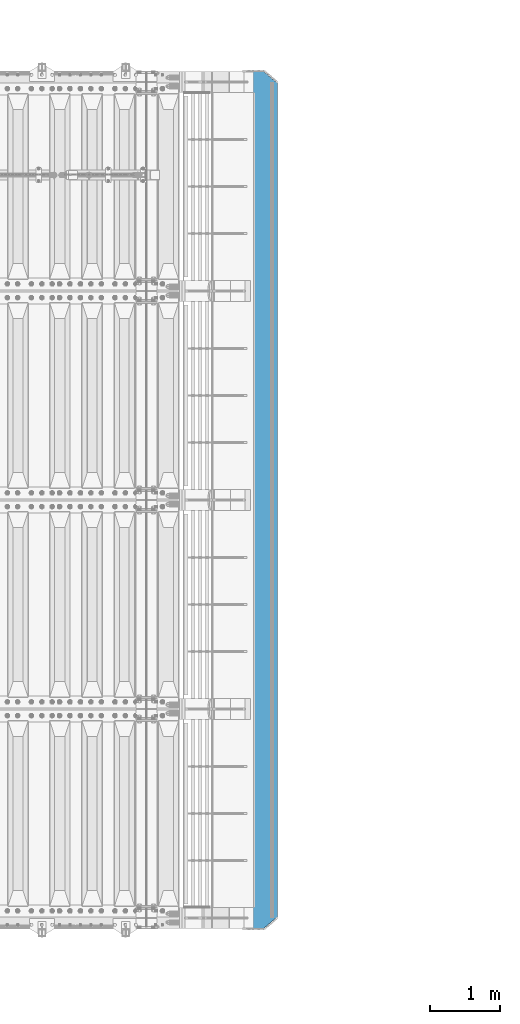
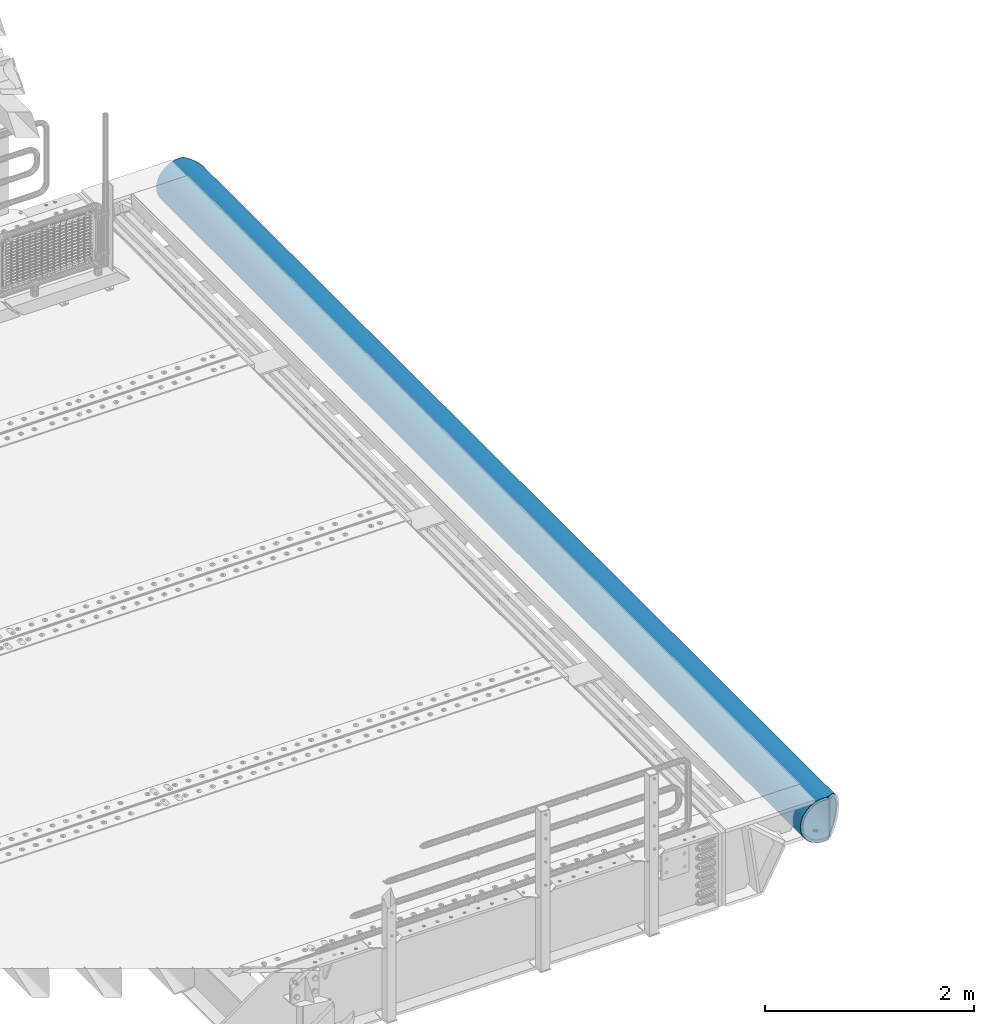
# One storey, part 132 of 257: 1 beam.
"""IFC2X3 building model written with IfcOpenShell, lengths in millimetres."""

import ifcopenshell
import ifcopenshell.guid

model = None  # the IFC model being written
_history = None  # IfcOwnerHistory: only IFC2X3 demands one
_inside = {}  # id of a spatial element -> (the spatial element, [elements in it])
_under = {}  # id of a project, library or spatial element -> (it, [spatial elements below it])
_declared = {}  # id of a project -> (the project, [libraries it declares])
_typed = {}  # id of a type object -> (the type object, [elements of that type])
_made_of = {}  # id of a material, layer set ... -> (it, [elements and type objects made of it])


def new_model(schema):
    """Start an empty IFC model of exactly this schema.

    Asked for "IFC4X3", IfcOpenShell would pick the latest addendum, in which some entities
    have other attributes; the version numbers below select the first issue.
    IFC2X3 requires an IfcOwnerHistory on every rooted entity: one is made here for all.
    """
    global model, _history
    if schema == "IFC4X3":
        model = ifcopenshell.file(schema_version=(4, 3, 0, 0))
    else:
        model = ifcopenshell.file(schema=schema)
    _inside.clear()
    _under.clear()
    _declared.clear()
    _typed.clear()
    _made_of.clear()
    _history = None
    if model.schema == "IFC2X3":
        org = make("IfcOrganization", Name="unknown")
        user = make(
            "IfcPersonAndOrganization",
            ThePerson=make("IfcPerson", FamilyName="unknown"),
            TheOrganization=org,
        )
        app = make(
            "IfcApplication",
            ApplicationDeveloper=org,
            Version="unknown",
            ApplicationFullName="unknown",
            ApplicationIdentifier="unknown",
        )
        _history = make(
            "IfcOwnerHistory",
            OwningUser=user,
            OwningApplication=app,
            ChangeAction="ADDED",
            CreationDate=0,
        )
    return model


def make(cls, **values):
    """One entity of the class cls with the attributes given. An attribute that is None is left unset."""
    return model.create_entity(
        cls, **{name: value for name, value in values.items() if value is not None}
    )


def rooted(cls, **values):
    """An entity with a GlobalId (a new one), such as an element, a storey or a relation."""
    return make(cls, GlobalId=ifcopenshell.guid.new(), OwnerHistory=_history, **values)


def si_unit(unit_type, name, prefix=None):
    """IfcSIUnit, for example si_unit("LENGTHUNIT", "METRE", prefix="MILLI")."""
    return make("IfcSIUnit", UnitType=unit_type, Prefix=prefix, Name=name)


def assignment(units):
    """IfcUnitAssignment: the units of a project."""
    return None if units is None else make("IfcUnitAssignment", Units=units)


def point(xyz):
    """IfcCartesianPoint."""
    return None if xyz is None else make("IfcCartesianPoint", Coordinates=xyz)


def direction(xyz):
    """IfcDirection."""
    return None if xyz is None else make("IfcDirection", DirectionRatios=xyz)


def frame(location, z_axis=None, x_axis=None):
    """IfcAxis2Placement3D, a coordinate frame: its origin and axes. An axis left out is left unset."""
    return make(
        "IfcAxis2Placement3D",
        Location=point(location),
        Axis=direction(z_axis),
        RefDirection=direction(x_axis),
    )


def origin_with_axes():
    """The frame at (0, 0, 0) with the z axis (0, 0, 1) and the x axis (1, 0, 0) written out."""
    return frame((0.0, 0.0, 0.0), z_axis=(0.0, 0.0, 1.0), x_axis=(1.0, 0.0, 0.0))


def place(relative_to, where):
    """IfcLocalPlacement: puts the frame where relative to a parent placement (None: the world)."""
    return make(
        "IfcLocalPlacement", PlacementRelTo=relative_to, RelativePlacement=where
    )


def context(
    kind, dimensions, precision=None, world=None, true_north=None, identifier=None
):
    """IfcGeometricRepresentationContext, for example the 3D "Model" context."""
    return make(
        "IfcGeometricRepresentationContext",
        ContextIdentifier=identifier,
        ContextType=kind,
        CoordinateSpaceDimension=dimensions,
        Precision=precision,
        WorldCoordinateSystem=world,
        TrueNorth=true_north,
    )


def subcontext(parent, identifier, kind, view, scale=None):
    """IfcGeometricRepresentationSubContext, for example "Body" below "Model"."""
    return make(
        "IfcGeometricRepresentationSubContext",
        ContextIdentifier=identifier,
        ContextType=kind,
        ParentContext=parent,
        TargetScale=scale,
        TargetView=view,
    )


def project(units=None, contexts=None):
    """IfcProject with its units and contexts."""
    return rooted(
        "IfcProject",
        Name="project",
        RepresentationContexts=contexts,
        UnitsInContext=assignment(units),
    )


def spatial(cls, under=None, at=None, **own):
    """A site, building, storey or space (cls), placed at a placement, below another one or the project."""
    s = rooted(cls, ObjectPlacement=at, **own)
    if under is not None:
        _under.setdefault(under.id(), (under, []))[1].append(s)
    return s


def faces_of(points, faces, orient=None, outer=None):
    """IfcFace entities. A face is a list of loops; a loop is a list of indices into points, from 0.

    orient and outer hold one flag for each loop. By default every Orientation is true, the
    first loop of a face is its IfcFaceOuterBound and the others are IfcFaceBound.
    """
    made = []
    for i, loops in enumerate(faces):
        bounds = []
        for j, loop in enumerate(loops):
            is_outer = j == 0 if outer is None else outer[i][j]
            bounds.append(
                make(
                    "IfcFaceOuterBound" if is_outer else "IfcFaceBound",
                    Bound=make("IfcPolyLoop", Polygon=[points[k] for k in loop]),
                    Orientation=True if orient is None else orient[i][j],
                )
            )
        made.append(make("IfcFace", Bounds=bounds))
    return made


def faceted_brep(points, faces, orient=None, outer=None, voids=None):
    """IfcFacetedBrep: a solid bounded by flat faces; with voids (closed shells), ...WithVoids."""
    shared = [point(p) for p in points]
    hull = make("IfcClosedShell", CfsFaces=faces_of(shared, faces, orient, outer))
    if voids is None:
        return make("IfcFacetedBrep", Outer=hull)
    return make(
        "IfcFacetedBrepWithVoids",
        Outer=hull,
        Voids=[
            make(cls, CfsFaces=faces_of(shared, fs, o, b)) for cls, fs, o, b in voids
        ],
    )


def shape(context_of_items, identifier, shape_type, items):
    """IfcShapeRepresentation: the items that make up one representation, for example the "Body"."""
    return make(
        "IfcShapeRepresentation",
        ContextOfItems=context_of_items,
        RepresentationIdentifier=identifier,
        RepresentationType=shape_type,
        Items=items,
    )


def material(Name=None, Category=None):
    """IfcMaterial."""
    return make("IfcMaterial", Name=Name, Category=Category)


def made_of(thing, what):
    """Note that an element or type object is made of a material, layer set ...; save() writes the relation."""
    if what is not None:
        _made_of.setdefault(what.id(), (what, []))[1].append(thing)
    return thing


def type_object(cls, material=None, **own):
    """A type object (cls), such as IfcWallType, which elements share."""
    return made_of(rooted(cls, **own), material)


def element(
    cls,
    number,
    at=None,
    inside=None,
    cuts=None,
    type_object=None,
    material=None,
    context=None,
    identifier="Body",
    shape_type=None,
    held_by="IfcProductDefinitionShape",
    body=None,
    shapes=None,
    **own,
):
    """One element of the class cls, such as IfcWall. Its Tag is "e" and its number.

    at: its placement. inside: the storey or other place that contains it. cuts: it is an
    opening in that element (IfcRelVoidsElement). A single representation is given by context,
    identifier, shape_type and body (its items); several are given by shapes. held_by: the class
    of the entity that holds the representations. save() writes the other relations.
    """
    e = rooted(cls, Tag="e%d" % number, ObjectPlacement=at, **own)
    if body is not None:
        shapes = [shape(context, identifier, shape_type, body)]
    if shapes is not None:
        e.Representation = make(held_by, Representations=shapes)
    if inside is not None:
        _inside.setdefault(inside.id(), (inside, []))[1].append(e)
    if cuts is not None:
        rooted(
            "IfcRelVoidsElement", RelatingBuildingElement=cuts, RelatedOpeningElement=e
        )
    if type_object is not None:
        _typed.setdefault(type_object.id(), (type_object, []))[1].append(e)
    return made_of(e, material)


def aggregate(whole, parts):
    """IfcRelAggregates: a whole, such as a stair, and the parts it consists of."""
    return rooted("IfcRelAggregates", RelatingObject=whole, RelatedObjects=parts)


def save(model, path):
    """Write the relations noted so far, then the file.

    IfcRelAggregates (storeys below a building ...), IfcRelContainedInSpatialStructure (elements
    in a storey), IfcRelDefinesByType, IfcRelAssociatesMaterial and IfcRelDeclares: one each for
    every whole, place, type object, material and project.
    """
    for whole, parts in _under.values():
        aggregate(whole, parts)
    for where, things in _inside.values():
        rooted(
            "IfcRelContainedInSpatialStructure",
            RelatedElements=things,
            RelatingStructure=where,
        )
    for kind, things in _typed.values():
        rooted("IfcRelDefinesByType", RelatedObjects=things, RelatingType=kind)
    for what, things in _made_of.values():
        rooted("IfcRelAssociatesMaterial", RelatedObjects=things, RelatingMaterial=what)
    for by, libraries in _declared.values():
        rooted("IfcRelDeclares", RelatingContext=by, RelatedDefinitions=libraries)
    model.write(path)


model = new_model("IFC2X3")

# Units and contexts
model_context = context("Model", 3, precision=1e-05, world=origin_with_axes())
body_context = subcontext(model_context, "Body", "Model", "MODEL_VIEW")
ifc_project = project(units=[si_unit("LENGTHUNIT", "METRE", prefix="MILLI"), si_unit("AREAUNIT", "SQUARE_METRE"), si_unit("VOLUMEUNIT", "CUBIC_METRE"), si_unit("MASSUNIT", "GRAM", prefix="KILO"), si_unit("TIMEUNIT", "SECOND"), si_unit("PLANEANGLEUNIT", "RADIAN"), si_unit("SOLIDANGLEUNIT", "STERADIAN"), si_unit("THERMODYNAMICTEMPERATUREUNIT", "DEGREE_CELSIUS"), si_unit("LUMINOUSINTENSITYUNIT", "LUMEN")], contexts=[model_context])

# Site, building, storey
site_placement = place(None, origin_with_axes())
site = spatial("IfcSite", under=ifc_project, at=site_placement, CompositionType="ELEMENT")
building_placement = place(site_placement, origin_with_axes())
building = spatial("IfcBuilding", under=site, at=building_placement, Name="Standard", CompositionType="ELEMENT")
storey_placement = place(building_placement, origin_with_axes())
storey = spatial("IfcBuildingStorey", under=building, at=storey_placement, Name="Undefined", CompositionType="ELEMENT", Elevation=0.0)

# Beam
ifc_material = material(Name="STEEL/S355N")
beam_type = type_object("IfcBeamType", PredefinedType="NOTDEFINED")
beam_placement = place(storey_placement, frame((60422.9988298906, 12150.0, -254.000000000001), z_axis=(0.0, 0.0, 1.0), x_axis=(0.0, -1.0, 0.0)))
element("IfcBeam", 1, at=beam_placement, inside=storey, type_object=beam_type, material=ifc_material, context=body_context, shape_type="Brep", body=[
    faceted_brep([(4626.90301168722, -9.56338969324133, -221.247344908114), (4626.90301168722, -9.56338969324133, -253.247344908114), (4625.0, 0.0, -254.0), (4625.0, 0.0, -222.0), (4632.32233047034, -17.6739734137809, -220.609028125963), (4632.32233047034, -17.6739734137809, -252.609028125964), (4640.43291419087, -23.0932921968997, -220.182518487905), (4640.43291419087, -23.0932921968997, -252.182518487906), (4650.0, -24.9963038841161, -220.032748220014), (4650.0, -24.9963038841161, -252.032748220015), (4659.56708580913, -23.0932921968997, -220.182518487905), (4659.56708580913, -23.0932921968997, -252.182518487906), (4667.67766952966, -17.6739734137809, -220.609028125963), (4667.67766952966, -17.6739734137809, -252.609028125964), (4673.09698831278, -9.56338969324133, -221.247344908114), (4673.09698831278, -9.56338969324133, -253.247344908114), (4675.0, 0.0, -222.0), (4675.0, 0.0, -254.0), (4673.09698831278, 9.57078192500921, -221.246763126853), (4673.09698831278, 9.57078192500921, -253.246763126854), (4667.67766952966, 17.6813656455488, -220.608446344703), (4667.67766952966, 17.6813656455488, -252.608446344704), (4659.56708580913, 23.1006844286676, -220.181936706645), (4659.56708580913, 23.1006844286676, -252.181936706646), (4650.0, 25.0036961158839, -220.032166438754), (4650.0, 25.0036961158839, -252.032166438755), (4640.43291419087, 23.1006844286676, -220.181936706645), (4640.43291419087, 23.1006844286676, -252.181936706646), (4632.32233047034, 17.6813656455488, -220.608446344703), (4632.32233047034, 17.6813656455488, -252.608446344704), (4626.90301168722, 9.57078192500921, -221.246763126853), (4626.90301168722, 9.57078192500921, -253.246763126854), (3126.90301168722, -9.56708580912527, -221.247054017483), (3126.90301168722, -9.56708580912527, -253.247054017484), (3125.0, 0.0, -254.0), (3125.0, 0.0, -222.0), (3132.32233047034, -17.6776695296649, -220.608737235333), (3132.32233047034, -17.6776695296649, -252.608737235334), (3140.43291419087, -23.0969883127837, -220.182227597274), (3140.43291419087, -23.0969883127837, -252.182227597275), (3150.0, -25.0, -220.032457329384), (3150.0, -25.0, -252.032457329385), (3159.56708580913, -23.0969883127837, -220.182227597274), (3159.56708580913, -23.0969883127837, -252.182227597275), (3167.67766952966, -17.6776695296649, -220.608737235333), (3167.67766952966, -17.6776695296649, -252.608737235334), (3173.09698831278, -9.56708580912527, -221.247054017483), (3173.09698831278, -9.56708580912527, -253.247054017484), (3175.0, 0.0, -222.0), (3175.0, 0.0, -254.0), (3173.09698831278, 9.56708580912527, -221.247054017484), (3173.09698831278, 9.56708580912527, -253.247054017485), (3167.67766952966, 17.6776695296649, -220.608737235334), (3167.67766952966, 17.6776695296649, -252.608737235334), (3159.56708580913, 23.0969883127837, -220.182227597276), (3159.56708580913, 23.0969883127837, -252.182227597277), (3150.0, 25.0, -220.032457329385), (3150.0, 25.0, -252.032457329385), (3140.43291419087, 23.0969883127837, -220.182227597276), (3140.43291419087, 23.0969883127837, -252.182227597277), (3132.32233047034, 17.6776695296649, -220.608737235334), (3132.32233047034, 17.6776695296649, -252.608737235334), (3126.90301168722, 9.56708580912527, -221.247054017484), (3126.90301168722, 9.56708580912527, -253.247054017485), (1626.90301168722, -9.56708580912527, -221.247054017484), (1626.90301168722, -9.56708580912527, -253.247054017485), (1625.0, 0.0, -254.0), (1625.0, 0.0, -222.0), (1632.32233047034, -17.6776695296649, -220.608737235334), (1632.32233047034, -17.6776695296649, -252.608737235334), (1640.43291419087, -23.0969883127837, -220.182227597276), (1640.43291419087, -23.0969883127837, -252.182227597275), (1650.0, -25.0, -220.032457329385), (1650.0, -25.0, -252.032457329385), (1659.56708580913, -23.0969883127837, -220.182227597276), (1659.56708580913, -23.0969883127837, -252.182227597275), (1667.67766952966, -17.6776695296649, -220.608737235334), (1667.67766952966, -17.6776695296649, -252.608737235334), (1673.09698831278, -9.56708580912527, -221.247054017484), (1673.09698831278, -9.56708580912527, -253.247054017485), (1675.0, 0.0, -222.0), (1675.0, 0.0, -254.0), (1673.09698831278, 9.56708580912527, -221.247054017483), (1673.09698831278, 9.56708580912527, -253.247054017484), (1667.67766952966, 17.6776695296649, -220.608737235333), (1667.67766952966, 17.6776695296649, -252.608737235334), (1659.56708580913, 23.0969883127837, -220.182227597275), (1659.56708580913, 23.0969883127837, -252.182227597275), (1650.0, 25.0, -220.032457329385), (1650.0, 25.0, -252.032457329385), (1640.43291419087, 23.0969883127837, -220.182227597275), (1640.43291419087, 23.0969883127837, -252.182227597275), (1632.32233047034, 17.6776695296649, -220.608737235333), (1632.32233047034, 17.6776695296649, -252.608737235334), (1626.90301168722, 9.56708580912527, -221.247054017483), (1626.90301168722, 9.56708580912527, -253.247054017484), (126.903011687218, -9.56708580912527, -221.247054017483), (126.903011687218, -9.56708580912527, -253.247054017484), (125.0, 0.0, -254.0), (125.0, 0.0, -222.0), (132.322330470337, -17.6776695296649, -220.608737235333), (132.322330470337, -17.6776695296649, -252.608737235333), (140.432914190873, -23.0969883127837, -220.182227597275), (140.432914190873, -23.0969883127837, -252.182227597275), (150.0, -25.0, -220.032457329385), (150.0, -25.0, -252.032457329384), (159.567085809127, -23.0969883127837, -220.182227597275), (159.567085809127, -23.0969883127837, -252.182227597275), (167.677669529663, -17.6776695296649, -220.608737235333), (167.677669529663, -17.6776695296649, -252.608737235333), (173.096988312782, -9.56708580912527, -221.247054017483), (173.096988312782, -9.56708580912527, -253.247054017484), (175.0, 0.0, -222.0), (175.0, 0.0, -254.0), (173.096988312782, 9.56708580912527, -221.247054017484), (173.096988312782, 9.56708580912527, -253.247054017484), (167.677669529663, 17.6776695296649, -220.608737235334), (167.677669529663, 17.6776695296649, -252.608737235334), (159.567085809127, 23.0969883127837, -220.182227597276), (159.567085809127, 23.0969883127837, -252.182227597276), (150.0, 25.0, -220.032457329384), (150.0, 25.0, -252.032457329385), (140.432914190873, 23.0969883127837, -220.182227597276), (140.432914190873, 23.0969883127837, -252.182227597276), (132.322330470337, 17.6776695296649, -220.608737235334), (132.322330470337, 17.6776695296649, -252.608737235334), (126.903011687218, 9.56708580912527, -221.247054017484), (126.903011687218, 9.56708580912527, -253.247054017484), (0.0, -34.7284512389306, -219.266811612121), (0.0, -68.6017727512371, -211.134546617524), (12300.0, -68.6017727512371, -211.134546617524), (12300.0, -34.7284512389306, -219.266811612121), (0.0, -100.785890942178, -197.803448369818), (12300.0, -100.785890942178, -197.803448369818), (0.0, -130.488326008926, -179.601772751238), (12300.0, -130.488326008926, -179.601772751238), (0.0, -156.977705423415, -156.977705423414), (12300.0, -156.977705423415, -156.977705423414), (0.0, -179.601772751237, -130.488326008929), (12300.0, -179.601772751237, -130.488326008929), (0.0, -197.803448369821, -100.785890942179), (12300.0, -197.803448369821, -100.785890942179), (0.0, -211.134546617526, -68.6017727512383), (12300.0, -211.134546617526, -68.6017727512383), (0.0, -219.26681161212, -34.7284512389313), (12300.0, -219.26681161212, -34.7284512389313), (0.0, -222.0, 0.0), (12300.0, -222.0, 0.0), (0.0, -219.26681161212, 34.7284512389313), (12300.0, -219.26681161212, 34.7284512389313), (0.0, -211.134546617526, 68.6017727512384), (12300.0, -211.134546617526, 68.6017727512384), (0.0, -197.803448369821, 100.785890942179), (12300.0, -197.803448369821, 100.785890942179), (0.0, -179.601772751237, 130.488326008929), (12300.0, -179.601772751237, 130.488326008929), (0.0, -156.977705423415, 156.977705423414), (12300.0, -156.977705423415, 156.977705423414), (0.0, -130.488326008926, 179.601772751238), (12300.0, -130.488326008926, 179.601772751238), (0.0, -100.785890942178, 197.803448369818), (12300.0, -100.785890942178, 197.803448369818), (0.0, -68.6017727512371, 211.134546617524), (12300.0, -68.6017727512371, 211.134546617524), (0.0, -34.7284512389306, 219.266811612121), (12300.0, -34.7284512389306, 219.266811612121), (0.0, 0.0, 222.0), (12300.0, 0.0, 222.0), (0.0, 34.7284512389306, 219.266811612121), (12300.0, 34.7284512389306, 219.266811612121), (12287.5916350975, 68.6017727512371, 211.134546617524), (12300.0, 54.0036961158839, 214.639234741096), (0.0, 54.0, 214.640122100011), (12.4115067427229, 68.6017727512371, 211.134546617524), (12260.2351351588, 100.785890942178, 197.803448369818), (39.7680069938251, 100.785890942178, 197.803448369818), (12234.9880658354, 130.488326008926, 179.601772751238), (65.0150766056395, 130.488326008926, 179.601772751238), (12212.4720937641, 156.977705423415, 156.977705423414), (87.5310489341209, 156.977705423415, 156.977705423414), (12193.2416369036, 179.601772751237, 130.488326008929), (106.7615060143, 179.601772751237, 130.488326008929), (12177.7702129239, 197.803448369821, 100.785890942179), (122.232930170652, 197.803448369821, 100.785890942179), (12166.4387796303, 211.134546617526, 68.6017727512383), (133.564363593714, 211.134546617526, 68.6017727512383), (12159.5263545172, 219.26681161212, 34.7284512389312), (140.476788785749, 219.26681161212, 34.7284512389312), (12157.203144432, 222.0, -2.8421709430404e-14), (142.799998897517, 222.0, -2.8421709430404e-14), (12159.5263545172, 219.26681161212, -34.7284512389313), (140.476788785749, 219.26681161212, -34.7284512389313), (12166.4387796303, 211.134546617526, -68.6017727512383), (133.564363593714, 211.134546617526, -68.6017727512383), (12177.7702129239, 197.803448369821, -100.785890942179), (122.232930170652, 197.803448369821, -100.785890942179), (12193.2416369036, 179.601772751237, -130.488326008929), (106.7615060143, 179.601772751237, -130.488326008929), (12212.4720937641, 156.977705423415, -156.977705423414), (87.5310489341209, 156.977705423415, -156.977705423414), (12234.9880658354, 130.488326008926, -179.601772751238), (65.0150766056395, 130.488326008926, -179.601772751238), (12260.2351351588, 100.785890942178, -197.803448369818), (39.7680069938251, 100.785890942178, -197.803448369818), (12287.5916350975, 68.6017727512371, -211.134546617524), (12.4115067427229, 68.6017727512371, -211.134546617524), (0.0, 34.7284512389306, -219.266811612121), (12300.0, 34.7284512389306, -219.266811612121), (12300.0, 54.0036961158839, -214.639234741096), (0.0, 54.0, -214.640122100011), (12140.5700428822, 241.568355138967, -78.4903165712366), (12153.5348359299, 226.315657143845, -115.313586933845), (146.468307441461, 226.315657143845, -115.313586933845), (159.433100637219, 241.568355138967, -78.4903165712366), (12171.2363750778, 205.490316571239, -149.297454082288), (128.766768091404, 205.490316571239, -149.297454082288), (12193.238789684, 179.605122421381, -179.605122421383), (106.764353233899, 179.605122421381, -179.605122421383), (12219.0003072791, 149.297454082291, -205.490316571237), (81.0028353445668, 149.297454082291, -205.490316571237), (12247.8865938023, 115.313586933844, -226.315657143845), (52.1165484913981, 115.313586933844, -226.315657143845), (12279.1863730114, 78.4903165712385, -241.568355138969), (20.8167689248367, 78.4903165712385, -241.568355138969), (12300.0, 54.0036961158839, -247.447072591956), (12300.0, 39.7343541202208, -250.872838511165), (0.0, 39.7343541202208, -250.872838511165), (0.0, 54.0, -247.447959950871), (0.0, 0.0, -222.0), (0.0, 0.0, -254.0), (0.0, -39.7343541202208, -250.872838511165), (0.0, -78.4903165712385, -241.568355138969), (0.0, -115.313586933844, -226.315657143845), (0.0, -149.297454082291, -205.490316571237), (0.0, -179.605122421381, -179.605122421383), (0.0, -205.490316571239, -149.297454082288), (0.0, -226.315657143845, -115.313586933845), (0.0, -241.568355138967, -78.4903165712367), (0.0, -250.872838511168, -39.7343541202187), (0.0, -254.0, 0.0), (0.0, -250.872838511168, 39.7343541202187), (0.0, -241.568355138967, 78.4903165712366), (0.0, -226.315657143845, 115.313586933845), (0.0, -205.490316571239, 149.297454082288), (0.0, -179.605122421381, 179.605122421383), (0.0, -149.297454082291, 205.490316571237), (0.0, -115.313586933844, 226.315657143845), (0.0, -78.4903165712385, 241.568355138969), (0.0, -39.7343541202208, 250.872838511165), (0.0, 0.0, 254.0), (0.0, 39.7343541202208, 250.872838511165), (0.0, 54.0, 247.447959950871), (12300.0, -39.7343541202208, -250.872838511165), (12300.0, -78.4903165712385, -241.568355138969), (12300.0, -115.313586933844, -226.315657143845), (12300.0, -149.297454082291, -205.490316571237), (12300.0, -179.605122421381, -179.605122421383), (12300.0, -205.490316571239, -149.297454082288), (12300.0, -226.315657143845, -115.313586933845), (12300.0, -241.568355138967, -78.4903165712367), (12300.0, -250.872838511168, -39.7343541202187), (12300.0, -254.0, 0.0), (12300.0, -250.872838511168, 39.7343541202187), (12300.0, -241.568355138967, 78.4903165712366), (12300.0, -226.315657143845, 115.313586933845), (12300.0, -205.490316571239, 149.297454082288), (12300.0, -179.605122421381, 179.605122421383), (12300.0, -149.297454082291, 205.490316571237), (12300.0, -115.313586933844, 226.315657143845), (12300.0, -78.4903165712385, 241.568355138969), (12300.0, -39.7343541202208, 250.872838511165), (12300.0, 0.0, 254.0), (12300.0, 39.7343541202208, 250.872838511165), (12300.0, 54.0036961158839, 247.447072591956), (12279.1863730114, 78.4903165712385, 241.568355138969), (20.8167689248367, 78.4903165712385, 241.568355138969), (12247.8865938023, 115.313586933844, 226.315657143845), (52.1165484913981, 115.313586933844, 226.315657143845), (12219.0003072791, 149.297454082291, 205.490316571237), (81.0028353445668, 149.297454082291, 205.490316571237), (12193.238789684, 179.605122421381, 179.605122421383), (106.764353233899, 179.605122421381, 179.605122421383), (12171.2363750778, 205.490316571239, 149.297454082288), (128.766768091404, 205.490316571239, 149.297454082288), (12153.5348359299, 226.315657143845, 115.313586933845), (146.468307441461, 226.315657143845, 115.313586933845), (12140.5700428822, 241.568355138967, 78.4903165712367), (159.433100637219, 241.568355138967, 78.4903165712367), (12129.999999832, 254.003700141948, 0.0), (12132.6612321673, 250.872838511168, -39.7343541202186), (167.341911442527, 250.872838511168, -39.7343541202186), (170.000001295226, 254.000003067893, 5.6843418860808e-14), (12132.6612321673, 250.872838511168, 39.7343541202187), (167.341911442527, 250.872838511168, 39.7343541202187), (12300.0, 0.0, -254.0), (12300.0, 0.0, -222.0), (12126.9030116872, -9.56338969324861, -221.247344908114), (12126.9030116872, -9.56338969324861, -253.247344908114), (12125.0, 0.0, -254.0), (12125.0, 0.0, -222.0), (12132.3223304703, -17.6739734137882, -220.609028125964), (12132.3223304703, -17.6739734137882, -252.609028125964), (12140.4329141909, -23.093292196907, -220.182518487906), (12140.4329141909, -23.093292196907, -252.182518487906), (12150.0, -24.9963038841233, -220.032748220015), (12150.0, -24.9963038841233, -252.032748220015), (12159.5670858091, -23.093292196907, -220.182518487906), (12159.5670858091, -23.093292196907, -252.182518487906), (12167.6776695297, -17.6739734137882, -220.609028125964), (12167.6776695297, -17.6739734137882, -252.609028125964), (12173.0969883128, -9.56338969324861, -221.247344908114), (12173.0969883128, -9.56338969324861, -253.247344908114), (12175.0, 0.0, -222.0), (12175.0, 0.0, -254.0), (12173.0969883128, 9.57078192500194, -221.246763126855), (12173.0969883128, 9.57078192500194, -253.246763126854), (12167.6776695297, 17.6813656455415, -220.608446344705), (12167.6776695297, 17.6813656455415, -252.608446344704), (12159.5670858091, 23.1006844286603, -220.181936706647), (12159.5670858091, 23.1006844286603, -252.181936706646), (12150.0, 25.0036961158767, -220.032166438755), (12150.0, 25.0036961158767, -252.032166438755), (12140.4329141909, 23.1006844286603, -220.181936706647), (12140.4329141909, 23.1006844286603, -252.181936706646), (12132.3223304703, 17.6813656455415, -220.608446344705), (12132.3223304703, 17.6813656455415, -252.608446344704), (12126.9030116872, 9.57078192500194, -221.246763126855), (12126.9030116872, 9.57078192500194, -253.246763126854), (10626.9030116872, -9.56338969324861, -221.247344908112), (10626.9030116872, -9.56338969324861, -253.247344908114), (10625.0, 0.0, -254.0), (10625.0, 0.0, -222.0), (10632.3223304703, -17.6739734137882, -220.609028125962), (10632.3223304703, -17.6739734137882, -252.609028125963), (10640.4329141909, -23.093292196907, -220.182518487904), (10640.4329141909, -23.093292196907, -252.182518487905), (10650.0, -24.9963038841233, -220.032748220013), (10650.0, -24.9963038841233, -252.032748220014), (10659.5670858091, -23.093292196907, -220.182518487904), (10659.5670858091, -23.093292196907, -252.182518487905), (10667.6776695297, -17.6739734137882, -220.609028125962), (10667.6776695297, -17.6739734137882, -252.609028125963), (10673.0969883128, -9.56338969324861, -221.247344908112), (10673.0969883128, -9.56338969324861, -253.247344908114), (10675.0, 0.0, -222.0), (10675.0, 0.0, -254.0), (10673.0969883128, 9.57078192500194, -221.246763126852), (10673.0969883128, 9.57078192500194, -253.246763126854), (10667.6776695297, 17.6813656455415, -220.608446344702), (10667.6776695297, 17.6813656455415, -252.608446344703), (10659.5670858091, 23.1006844286603, -220.181936706644), (10659.5670858091, 23.1006844286603, -252.181936706645), (10650.0, 25.0036961158767, -220.032166438753), (10650.0, 25.0036961158767, -252.032166438754), (10640.4329141909, 23.1006844286603, -220.181936706644), (10640.4329141909, 23.1006844286603, -252.181936706645), (10632.3223304703, 17.6813656455415, -220.608446344702), (10632.3223304703, 17.6813656455415, -252.608446344703), (10626.9030116872, 9.57078192500194, -221.246763126852), (10626.9030116872, 9.57078192500194, -253.246763126854), (9132.32233047034, 17.6813656455415, -252.608446344704), (9126.90301168722, 9.57078192500194, -253.246763126854), (9125.0, 0.0, -254.0), (7675.0, 0.0, -254.0), (7673.09698831278, 9.57078192500194, -253.246763126853), (7667.67766952966, 17.6813656455415, -252.608446344703), (7659.56708580913, 23.1006844286603, -252.181936706644), (7650.0, 25.0036961158767, -252.032166438753), (7640.43291419087, 23.1006844286603, -252.181936706644), (7632.32233047034, 17.6813656455415, -252.608446344703), (7626.90301168722, 9.57078192500194, -253.246763126853), (7625.0, 0.0, -254.0), (6175.0, 0.0, -254.0), (6173.09698831278, 9.57078192500194, -253.246763126855), (6167.67766952966, 17.6813656455415, -252.608446344705), (6159.56708580913, 23.1006844286603, -252.181936706647), (6150.0, 25.0036961158767, -252.032166438756), (6140.43291419087, 23.1006844286603, -252.181936706647), (6132.32233047034, 17.6813656455415, -252.608446344705), (6126.90301168722, 9.57078192500194, -253.246763126855), (6125.0, 0.0, -254.0), (9175.0, 0.0, -254.0), (9173.09698831278, 9.57078192500194, -253.246763126854), (9167.67766952966, 17.6813656455415, -252.608446344704), (9159.56708580913, 23.1006844286603, -252.181936706646), (9150.0, 25.0036961158767, -252.032166438755), (9140.43291419087, 23.1006844286603, -252.181936706646), (7667.67766952966, 17.6813656455415, -220.608446344703), (7673.09698831278, 9.57078192500194, -221.246763126853), (7659.56708580913, 23.1006844286603, -220.181936706645), (7650.0, 25.0036961158767, -220.032166438754), (7640.43291419087, 23.1006844286603, -220.181936706645), (7632.32233047034, 17.6813656455415, -220.608446344703), (7626.90301168722, 9.57078192500194, -221.246763126853), (7625.0, 0.0, -222.0), (7626.90301168722, -9.56338969324861, -221.247344908114), (7626.90301168722, -9.56338969324861, -253.247344908112), (7632.32233047034, -17.6739734137882, -220.609028125964), (7632.32233047034, -17.6739734137882, -252.609028125961), (7640.43291419087, -23.093292196907, -220.182518487906), (7640.43291419087, -23.093292196907, -252.182518487902), (7650.0, -24.9963038841233, -220.032748220015), (7650.0, -24.9963038841233, -252.032748220011), (7659.56708580913, -23.093292196907, -220.182518487906), (7659.56708580913, -23.093292196907, -252.182518487902), (7667.67766952966, -17.6739734137882, -220.609028125964), (7667.67766952966, -17.6739734137882, -252.609028125961), (7673.09698831278, -9.56338969324861, -221.247344908114), (7673.09698831278, -9.56338969324861, -253.247344908112), (7675.0, 0.0, -222.0), (9167.67766952966, 17.6813656455415, -220.608446344704), (9173.09698831278, 9.57078192500194, -221.246763126854), (9175.0, 0.0, -222.0), (6125.0, 0.0, -222.0), (6126.90301168722, 9.57078192500194, -221.246763126856), (6132.32233047034, 17.6813656455415, -220.608446344706), (6140.43291419087, 23.1006844286603, -220.181936706647), (6150.0, 25.0036961158767, -220.032166438756), (6159.56708580913, 23.1006844286603, -220.181936706647), (6167.67766952966, 17.6813656455415, -220.608446344706), (6173.09698831278, 9.57078192500194, -221.246763126856), (6175.0, 0.0, -222.0), (9125.0, 0.0, -222.0), (9126.90301168722, 9.57078192500194, -221.246763126854), (9132.32233047034, 17.6813656455415, -220.608446344704), (9140.43291419087, 23.1006844286603, -220.181936706646), (9150.0, 25.0036961158767, -220.032166438754), (9159.56708580913, 23.1006844286603, -220.181936706646), (6173.09698831278, -9.56338969324861, -221.247344908114), (6167.67766952966, -17.6739734137882, -220.609028125964), (6159.56708580913, -23.093292196907, -220.182518487906), (6150.0, -24.9963038841233, -220.032748220015), (6140.43291419087, -23.093292196907, -220.182518487906), (6132.32233047034, -17.6739734137882, -220.609028125964), (6126.90301168722, -9.56338969324861, -221.247344908114), (9173.09698831278, -9.56338969324861, -221.247344908111), (9167.67766952966, -17.6739734137882, -220.609028125961), (9159.56708580913, -23.093292196907, -220.182518487903), (9150.0, -24.9963038841233, -220.032748220012), (9140.43291419087, -23.093292196907, -220.182518487903), (9132.32233047034, -17.6739734137882, -220.609028125961), (9126.90301168722, -9.56338969324861, -221.247344908111), (9132.32233047034, -17.6739734137882, -252.609028125962), (9126.90301168722, -9.56338969324861, -253.247344908113), (9140.43291419087, -23.093292196907, -252.182518487904), (9150.0, -24.9963038841233, -252.032748220013), (9159.56708580913, -23.093292196907, -252.182518487904), (9167.67766952966, -17.6739734137882, -252.609028125962), (9173.09698831278, -9.56338969324861, -253.247344908113), (6126.90301168722, -9.56338969324861, -253.247344908113), (6132.32233047034, -17.6739734137882, -252.609028125963), (6140.43291419087, -23.093292196907, -252.182518487904), (6150.0, -24.9963038841233, -252.032748220013), (6159.56708580913, -23.093292196907, -252.182518487904), (6167.67766952966, -17.6739734137882, -252.609028125963), (6173.09698831278, -9.56338969324861, -253.247344908113)], [[[0, 1, 2, 3]], [[4, 5, 1, 0]], [[6, 7, 5, 4]], [[8, 9, 7, 6]], [[10, 11, 9, 8]], [[12, 13, 11, 10]], [[14, 15, 13, 12]], [[16, 17, 15, 14]], [[18, 19, 17, 16]], [[20, 21, 19, 18]], [[22, 23, 21, 20]], [[24, 25, 23, 22]], [[26, 27, 25, 24]], [[28, 29, 27, 26]], [[30, 31, 29, 28]], [[3, 2, 31, 30]], [[32, 33, 34, 35]], [[36, 37, 33, 32]], [[38, 39, 37, 36]], [[40, 41, 39, 38]], [[42, 43, 41, 40]], [[44, 45, 43, 42]], [[46, 47, 45, 44]], [[48, 49, 47, 46]], [[50, 51, 49, 48]], [[52, 53, 51, 50]], [[54, 55, 53, 52]], [[56, 57, 55, 54]], [[58, 59, 57, 56]], [[60, 61, 59, 58]], [[62, 63, 61, 60]], [[35, 34, 63, 62]], [[64, 65, 66, 67]], [[68, 69, 65, 64]], [[70, 71, 69, 68]], [[72, 73, 71, 70]], [[74, 75, 73, 72]], [[76, 77, 75, 74]], [[78, 79, 77, 76]], [[80, 81, 79, 78]], [[82, 83, 81, 80]], [[84, 85, 83, 82]], [[86, 87, 85, 84]], [[88, 89, 87, 86]], [[90, 91, 89, 88]], [[92, 93, 91, 90]], [[94, 95, 93, 92]], [[67, 66, 95, 94]], [[96, 97, 98, 99]], [[100, 101, 97, 96]], [[102, 103, 101, 100]], [[104, 105, 103, 102]], [[106, 107, 105, 104]], [[108, 109, 107, 106]], [[110, 111, 109, 108]], [[112, 113, 111, 110]], [[114, 115, 113, 112]], [[116, 117, 115, 114]], [[118, 119, 117, 116]], [[120, 121, 119, 118]], [[122, 123, 121, 120]], [[124, 125, 123, 122]], [[126, 127, 125, 124]], [[99, 98, 127, 126]], [[128, 129, 130, 131]], [[129, 132, 133, 130]], [[132, 134, 135, 133]], [[134, 136, 137, 135]], [[136, 138, 139, 137]], [[138, 140, 141, 139]], [[140, 142, 143, 141]], [[142, 144, 145, 143]], [[144, 146, 147, 145]], [[146, 148, 149, 147]], [[148, 150, 151, 149]], [[150, 152, 153, 151]], [[152, 154, 155, 153]], [[154, 156, 157, 155]], [[156, 158, 159, 157]], [[158, 160, 161, 159]], [[160, 162, 163, 161]], [[162, 164, 165, 163]], [[164, 166, 167, 165]], [[166, 168, 169, 167]], [[170, 171, 169, 168, 172, 173]], [[174, 170, 173, 175]], [[176, 174, 175, 177]], [[178, 176, 177, 179]], [[180, 178, 179, 181]], [[182, 180, 181, 183]], [[184, 182, 183, 185]], [[186, 184, 185, 187]], [[188, 186, 187, 189]], [[190, 188, 189, 191]], [[192, 190, 191, 193]], [[194, 192, 193, 195]], [[196, 194, 195, 197]], [[198, 196, 197, 199]], [[200, 198, 199, 201]], [[202, 200, 201, 203]], [[204, 202, 203, 205]], [[206, 207, 208, 204, 205, 209]], [[210, 211, 212, 213]], [[211, 214, 215, 212]], [[214, 216, 217, 215]], [[216, 218, 219, 217]], [[218, 220, 221, 219]], [[220, 222, 223, 221]], [[222, 224, 225, 226, 227, 223]], [[168, 166, 164, 162, 160, 158, 156, 154, 152, 150, 148, 146, 144, 142, 140, 138, 136, 134, 132, 129, 128, 228, 206, 209, 227, 226, 229, 230, 231, 232, 233, 234, 235, 236, 237, 238, 239, 240, 241, 242, 243, 244, 245, 246, 247, 248, 249, 250, 251, 172]], [[231, 230, 252, 253]], [[232, 231, 253, 254]], [[233, 232, 254, 255]], [[234, 233, 255, 256]], [[235, 234, 256, 257]], [[236, 235, 257, 258]], [[237, 236, 258, 259]], [[238, 237, 259, 260]], [[239, 238, 260, 261]], [[240, 239, 261, 262]], [[241, 240, 262, 263]], [[242, 241, 263, 264]], [[243, 242, 264, 265]], [[244, 243, 265, 266]], [[245, 244, 266, 267]], [[246, 245, 267, 268]], [[247, 246, 268, 269]], [[248, 247, 269, 270]], [[249, 248, 270, 271]], [[250, 249, 271, 272]], [[250, 272, 273, 274, 275, 251]], [[274, 276, 277, 275]], [[276, 278, 279, 277]], [[278, 280, 281, 279]], [[280, 282, 283, 281]], [[282, 284, 285, 283]], [[284, 286, 287, 285]], [[288, 289, 290, 291]], [[292, 288, 291, 293]], [[286, 292, 293, 287]], [[291, 290, 213, 212, 215, 217, 219, 221, 223, 227, 209, 205, 203, 201, 199, 197, 195, 193, 191, 189, 187, 185, 183, 181, 179, 177, 175, 173, 172, 251, 275, 277, 279, 281, 283, 285, 287, 293]], [[289, 210, 213, 290]], [[288, 292, 286, 284, 282, 280, 278, 276, 274, 273, 171, 170, 174, 176, 178, 180, 182, 184, 186, 188, 190, 192, 194, 196, 198, 200, 202, 204, 208, 224, 222, 220, 218, 216, 214, 211, 210, 289]], [[272, 271, 270, 269, 268, 267, 266, 265, 264, 263, 262, 261, 260, 259, 258, 257, 256, 255, 254, 253, 252, 294, 225, 224, 208, 207, 295, 131, 130, 133, 135, 137, 139, 141, 143, 145, 147, 149, 151, 153, 155, 157, 159, 161, 163, 165, 167, 169, 171, 273]], [[296, 297, 298, 299]], [[300, 301, 297, 296]], [[302, 303, 301, 300]], [[304, 305, 303, 302]], [[306, 307, 305, 304]], [[308, 309, 307, 306]], [[310, 311, 309, 308]], [[312, 313, 311, 310]], [[314, 315, 313, 312]], [[316, 317, 315, 314]], [[318, 319, 317, 316]], [[320, 321, 319, 318]], [[322, 323, 321, 320]], [[324, 325, 323, 322]], [[326, 327, 325, 324]], [[299, 298, 327, 326]], [[328, 329, 330, 331]], [[332, 333, 329, 328]], [[334, 335, 333, 332]], [[336, 337, 335, 334]], [[338, 339, 337, 336]], [[340, 341, 339, 338]], [[342, 343, 341, 340]], [[344, 345, 343, 342]], [[346, 347, 345, 344]], [[348, 349, 347, 346]], [[350, 351, 349, 348]], [[352, 353, 351, 350]], [[354, 355, 353, 352]], [[356, 357, 355, 354]], [[358, 359, 357, 356]], [[331, 330, 359, 358]], [[360, 361, 362, 363, 364, 365, 366, 367, 368, 369, 370, 371, 372, 373, 374, 375, 376, 377, 378, 379, 380, 17, 19, 21, 23, 25, 27, 29, 31, 2, 49, 51, 53, 55, 57, 59, 61, 63, 34, 81, 83, 85, 87, 89, 91, 93, 95, 66, 113, 115, 117, 119, 121, 123, 125, 127, 98, 229, 226, 225, 294, 313, 315, 317, 319, 321, 323, 325, 327, 298, 345, 347, 349, 351, 353, 355, 357, 359, 330, 381, 382, 383, 384, 385, 386]], [[387, 365, 364, 388]], [[389, 366, 365, 387]], [[390, 367, 366, 389]], [[391, 368, 367, 390]], [[392, 369, 368, 391]], [[393, 370, 369, 392]], [[394, 371, 370, 393]], [[395, 396, 371, 394]], [[397, 398, 396, 395]], [[399, 400, 398, 397]], [[401, 402, 400, 399]], [[403, 404, 402, 401]], [[405, 406, 404, 403]], [[407, 408, 406, 405]], [[409, 363, 408, 407]], [[388, 364, 363, 409]], [[410, 411, 412, 331, 358, 356, 354, 352, 350, 348, 346, 344, 299, 326, 324, 322, 320, 318, 316, 314, 312, 295, 207, 206, 228, 99, 126, 124, 122, 120, 118, 116, 114, 112, 67, 94, 92, 90, 88, 86, 84, 82, 80, 35, 62, 60, 58, 56, 54, 52, 50, 48, 3, 30, 28, 26, 24, 22, 20, 18, 16, 413, 414, 415, 416, 417, 418, 419, 420, 421, 394, 393, 392, 391, 390, 389, 387, 388, 409, 422, 423, 424, 425, 426, 427]], [[409, 407, 405, 403, 401, 399, 397, 395, 394, 421, 428, 429, 430, 431, 432, 433, 434, 413, 16, 14, 12, 10, 8, 6, 4, 0, 3, 48, 46, 44, 42, 40, 38, 36, 32, 35, 80, 78, 76, 74, 72, 70, 68, 64, 67, 112, 110, 108, 106, 104, 102, 100, 96, 99, 228, 128, 131, 295, 312, 310, 308, 306, 304, 302, 300, 296, 299, 344, 342, 340, 338, 336, 334, 332, 328, 331, 412, 435, 436, 437, 438, 439, 440, 441, 422]], [[440, 442, 443, 441]], [[439, 444, 442, 440]], [[438, 445, 444, 439]], [[437, 446, 445, 438]], [[436, 447, 446, 437]], [[435, 448, 447, 436]], [[412, 381, 448, 435]], [[411, 382, 381, 412]], [[410, 383, 382, 411]], [[427, 384, 383, 410]], [[426, 385, 384, 427]], [[425, 386, 385, 426]], [[424, 360, 386, 425]], [[423, 361, 360, 424]], [[422, 362, 361, 423]], [[441, 443, 362, 422]], [[442, 444, 445, 446, 447, 448, 381, 330, 329, 333, 335, 337, 339, 341, 343, 345, 298, 297, 301, 303, 305, 307, 309, 311, 313, 294, 252, 230, 229, 98, 97, 101, 103, 105, 107, 109, 111, 113, 66, 65, 69, 71, 73, 75, 77, 79, 81, 34, 33, 37, 39, 41, 43, 45, 47, 49, 2, 1, 5, 7, 9, 11, 13, 15, 17, 380, 449, 450, 451, 452, 453, 454, 455, 372, 371, 396, 398, 400, 402, 404, 406, 408, 363, 362, 443]], [[432, 451, 450, 433]], [[431, 452, 451, 432]], [[430, 453, 452, 431]], [[429, 454, 453, 430]], [[428, 455, 454, 429]], [[421, 372, 455, 428]], [[420, 373, 372, 421]], [[419, 374, 373, 420]], [[418, 375, 374, 419]], [[417, 376, 375, 418]], [[416, 377, 376, 417]], [[415, 378, 377, 416]], [[414, 379, 378, 415]], [[413, 380, 379, 414]], [[434, 449, 380, 413]], [[433, 450, 449, 434]]]),
])

save(model, "model.ifc")
